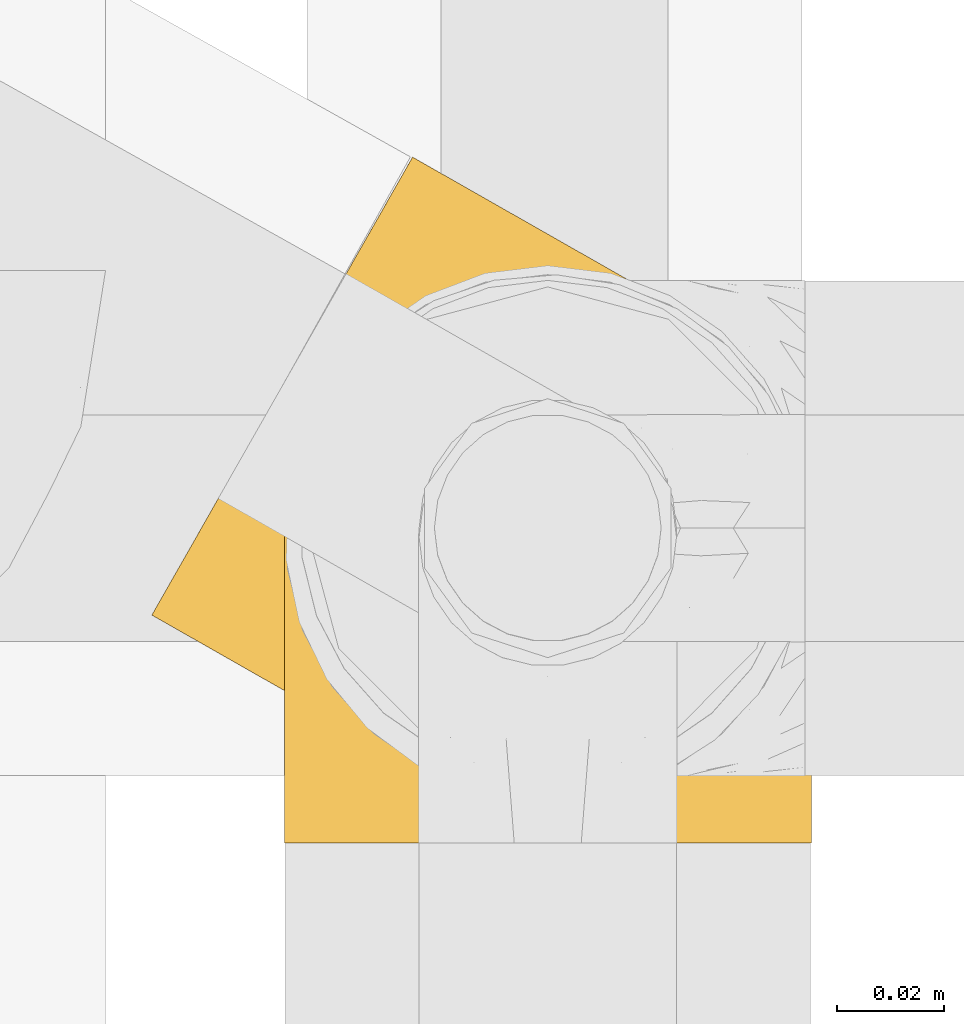
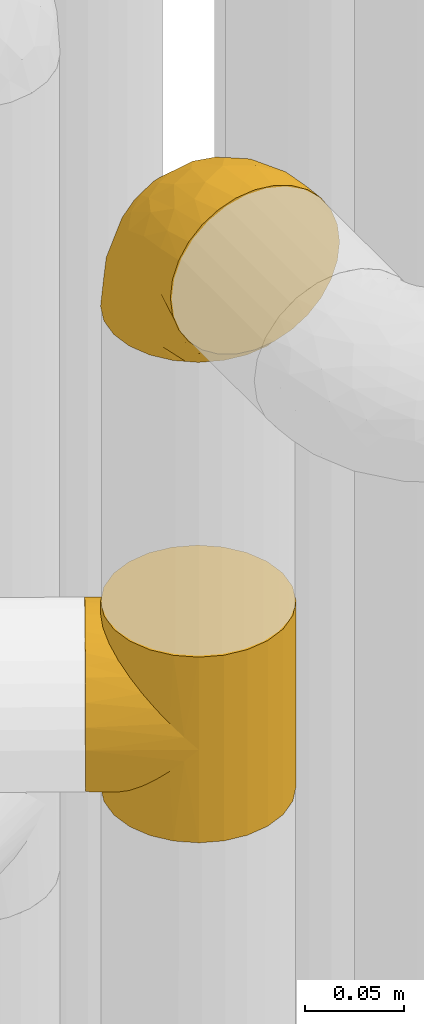
# One storey, part 165 of 827: 2 coverings.
"""IFC2X3 building model written with IfcOpenShell, lengths in millimetres."""

from ifc_helpers import new_model, entity, si_unit, converted_unit, derived_unit, direction, frame, origin, place, context, subcontext, project, spatial, faceted_brep, element, save


model = new_model("IFC2X3")

# Units and contexts
model_context = context("Model", 3, precision=0.01, world=origin(), true_north=direction((6.12303176911189e-17, 1.0)))
body_context = subcontext(model_context, "Body", "Model", "MODEL_VIEW")
ifc_project = project(units=[si_unit("LENGTHUNIT", "METRE", prefix="MILLI"), si_unit("AREAUNIT", "SQUARE_METRE"), si_unit("VOLUMEUNIT", "CUBIC_METRE"), converted_unit("PLANEANGLEUNIT", "DEGREE", entity("IfcRatioMeasure", 0.0174532925199433), si_unit("PLANEANGLEUNIT", "RADIAN"), dimensions=[0, 0, 0, 0, 0, 0, 0]), si_unit("MASSUNIT", "GRAM", prefix="KILO"), derived_unit("MASSDENSITYUNIT", [(si_unit("MASSUNIT", "GRAM", prefix="KILO"), 1), (si_unit("LENGTHUNIT", "METRE"), -3)]), derived_unit("MOMENTOFINERTIAUNIT", [(si_unit("LENGTHUNIT", "METRE"), 4)]), si_unit("TIMEUNIT", "SECOND"), si_unit("FREQUENCYUNIT", "HERTZ"), si_unit("THERMODYNAMICTEMPERATUREUNIT", "DEGREE_CELSIUS"), derived_unit("THERMALTRANSMITTANCEUNIT", [(si_unit("MASSUNIT", "GRAM", prefix="KILO"), 1), (si_unit("THERMODYNAMICTEMPERATUREUNIT", "KELVIN"), -1), (si_unit("TIMEUNIT", "SECOND"), -3)]), derived_unit("VOLUMETRICFLOWRATEUNIT", [(si_unit("LENGTHUNIT", "METRE"), 3), (si_unit("TIMEUNIT", "SECOND"), -1)]), derived_unit("MASSFLOWRATEUNIT", [(si_unit("MASSUNIT", "GRAM", prefix="KILO"), 1), (si_unit("TIMEUNIT", "SECOND"), -1)]), derived_unit("ROTATIONALFREQUENCYUNIT", [(si_unit("TIMEUNIT", "SECOND"), -1)]), si_unit("ELECTRICCURRENTUNIT", "AMPERE"), si_unit("ELECTRICVOLTAGEUNIT", "VOLT"), si_unit("POWERUNIT", "WATT"), si_unit("FORCEUNIT", "NEWTON", prefix="KILO"), si_unit("ILLUMINANCEUNIT", "LUX"), si_unit("LUMINOUSFLUXUNIT", "LUMEN"), si_unit("LUMINOUSINTENSITYUNIT", "CANDELA"), derived_unit("USERDEFINED", [(si_unit("MASSUNIT", "GRAM", prefix="KILO"), -1), (si_unit("LENGTHUNIT", "METRE"), -2), (si_unit("TIMEUNIT", "SECOND"), 3), (si_unit("LUMINOUSFLUXUNIT", "LUMEN"), 1)]), derived_unit("LINEARVELOCITYUNIT", [(si_unit("LENGTHUNIT", "METRE"), 1), (si_unit("TIMEUNIT", "SECOND"), -1)]), si_unit("PRESSUREUNIT", "PASCAL"), derived_unit("USERDEFINED", [(si_unit("LENGTHUNIT", "METRE"), -2), (si_unit("MASSUNIT", "GRAM", prefix="KILO"), 1), (si_unit("TIMEUNIT", "SECOND"), -2)]), derived_unit("LINEARFORCEUNIT", [(si_unit("MASSUNIT", "GRAM", prefix="KILO"), 1), (si_unit("LENGTHUNIT", "METRE"), 1), (si_unit("TIMEUNIT", "SECOND"), -2), (si_unit("LENGTHUNIT", "METRE"), -1)]), derived_unit("PLANARFORCEUNIT", [(si_unit("MASSUNIT", "GRAM", prefix="KILO"), 1), (si_unit("LENGTHUNIT", "METRE"), 1), (si_unit("TIMEUNIT", "SECOND"), -2), (si_unit("LENGTHUNIT", "METRE"), -2)])], contexts=[model_context])

# Site, building, storey
site_placement = place(None, origin())
site = spatial("IfcSite", under=ifc_project, at=site_placement, CompositionType="ELEMENT")
building_placement = place(site_placement, origin())
building = spatial("IfcBuilding", under=site, at=building_placement, CompositionType="ELEMENT")
storey_placement = place(building_placement, frame((0.0, 0.0, 28200.0)))
storey = spatial("IfcBuildingStorey", under=building, at=storey_placement, Name="08", CompositionType="ELEMENT", Elevation=28200.0)

# Coverings
covering_1_placement = place(storey_placement, frame((35653.34, 11503.72, 2248.0)))
element("IfcCovering", 1, at=covering_1_placement, inside=storey, Name=":ADSK_", ObjectType=":ADSK_", PredefinedType="INSULATION", context=body_context, shape_type="Brep", body=[
    faceted_brep([(93.79, 96.34, 50.38), (99.76, 93.46, 0.0), (87.88, 98.3, 0.0), (75.15, 99.89, 0.0), (80.71, 99.61, 37.4), (66.46, 99.07, 25.28), (62.44, 98.14, 0.0), (73.7, 99.86, 31.18), (99.76, 93.46, 57.0), (93.79, 96.34, 63.62), (99.76, 93.46, 114.0), (35.42, 78.88, 8.29), (36.61, 80.17, 0.0), (34.67, 77.62, 0.0), (87.43, 98.41, 43.83), (32.73, 75.06, 7.85), (32.73, 75.06, 0.0), (34.67, 77.62, 114.0), (32.73, 75.06, 106.15), (32.73, 75.06, 114.0), (59.07, 97.09, 19.84), (50.62, 93.16, 0.0), (45.55, 89.22, 0.0), (40.48, 85.29, 0.0), (41.34, 85.85, 10.0), (38.11, 82.7, 8.74), (51.69, 93.77, 15.07), (44.58, 89.0, 11.25), (38.55, 82.73, 0.0), (31.52, 72.09, 0.0), (30.32, 69.12, 0.0), (30.66, 70.32, 8.4), (28.59, 65.57, 8.94), (29.11, 66.15, 0.0), (27.9, 63.18, 0.0), (26.56, 55.83, 12.0), (27.1, 56.81, 0.0), (26.3, 50.45, 0.0), (27.57, 60.7, 10.47), (26.48, 46.46, 16.57), (27.17, 44.09, 0.0), (28.03, 37.82, 22.18), (26.52, 51.14, 14.29), (31.7, 72.69, 8.12), (28.05, 37.74, 0.0), (30.87, 30.04, 28.5), (33.03, 25.91, 0.0), (34.77, 23.16, 35.29), (40.9, 15.78, 0.0), (45.02, 12.15, 49.65), (51.13, 8.03, 0.0), (31.7, 72.69, 105.88), (39.53, 17.2, 42.38), (51.13, 8.03, 57.0), (45.02, 12.15, 64.35), (51.13, 8.03, 114.0), (100.28, 8.33, 114.0), (110.41, 16.2, 114.0), (118.16, 26.43, 114.0), (123.0, 38.31, 114.0), (124.6, 51.04, 114.0), (122.84, 63.75, 114.0), (117.86, 75.58, 114.0), (109.99, 85.71, 114.0), (87.88, 98.3, 114.0), (75.15, 99.89, 114.0), (62.44, 98.14, 114.0), (50.62, 93.16, 114.0), (45.55, 89.22, 114.0), (40.48, 85.29, 114.0), (38.55, 82.73, 114.0), (36.61, 80.17, 114.0), (31.52, 72.09, 114.0), (30.32, 69.12, 114.0), (29.11, 66.15, 114.0), (27.9, 63.18, 114.0), (27.1, 56.81, 114.0), (26.3, 50.45, 114.0), (27.17, 44.09, 114.0), (28.05, 37.74, 114.0), (33.03, 25.91, 114.0), (40.9, 15.78, 114.0), (63.01, 3.19, 114.0), (75.74, 1.6, 114.0), (88.45, 3.35, 114.0), (109.99, 85.71, 0.0), (117.86, 75.58, 0.0), (122.84, 63.75, 0.0), (124.6, 51.04, 0.0), (123.0, 38.31, 0.0), (118.16, 26.43, 0.0), (110.41, 16.2, 0.0), (100.28, 8.33, 0.0), (88.45, 3.35, 0.0), (75.74, 1.6, 0.0), (63.01, 3.19, 0.0), (87.43, 98.41, 70.17), (80.71, 99.61, 76.6), (35.42, 78.88, 105.71), (73.7, 99.86, 82.82), (66.46, 99.07, 88.72), (38.11, 82.7, 105.26), (59.07, 97.09, 94.16), (51.69, 93.77, 98.93), (41.34, 85.85, 104.0), (44.58, 89.0, 102.75), (26.56, 55.83, 102.0), (27.57, 60.7, 103.53), (26.48, 46.46, 97.43), (28.59, 65.57, 105.06), (28.03, 37.82, 91.82), (26.52, 51.14, 99.71), (30.66, 70.32, 105.6), (34.77, 23.16, 78.71), (39.53, 17.2, 71.62), (30.87, 30.04, 85.5), (49.4, 120.2, 44.28), (46.97, 115.94, 32.42), (43.11, 109.15, 22.25), (38.07, 100.3, 14.43), (35.14, 95.15, 11.98), (32.21, 90.0, 9.52), (30.63, 87.24, 9.11), (29.06, 84.47, 8.69), (27.49, 81.71, 8.27), (25.91, 78.95, 7.85), (24.34, 76.18, 8.27), (22.77, 73.42, 8.69), (21.19, 70.65, 9.11), (19.62, 67.89, 9.52), (16.69, 62.74, 11.98), (13.75, 57.59, 14.43), (11.24, 53.17, 18.34), (8.72, 48.74, 22.25), (4.85, 41.96, 32.42), (2.42, 37.69, 44.28), (1.6, 36.23, 57.0), (2.42, 37.69, 69.72), (4.85, 41.96, 81.57), (8.72, 48.74, 91.75), (11.24, 53.17, 95.66), (13.75, 57.59, 99.57), (16.69, 62.74, 102.02), (19.62, 67.89, 104.48), (21.19, 70.65, 104.89), (22.77, 73.42, 105.31), (24.34, 76.18, 105.73), (25.91, 78.95, 106.15), (27.49, 81.71, 105.73), (29.06, 84.47, 105.31), (30.63, 87.24, 104.89), (32.21, 90.0, 104.48), (35.14, 95.15, 102.02), (38.07, 100.3, 99.57), (43.11, 109.15, 91.75), (46.97, 115.94, 81.57), (49.4, 120.2, 69.72), (50.23, 121.66, 57.0)], [[[0, 1, 2]], [[2, 3, 4]], [[5, 3, 6]], [[5, 7, 3]], [[0, 8, 1]], [[8, 9, 10]], [[11, 12, 13]], [[4, 14, 2]], [[7, 4, 3]], [[0, 2, 14]], [[15, 13, 16]], [[17, 18, 19]], [[20, 6, 21]], [[22, 23, 24]], [[15, 11, 13]], [[23, 25, 24]], [[26, 20, 21]], [[27, 21, 22]], [[27, 22, 24]], [[25, 12, 11]], [[25, 23, 28, 12]], [[26, 21, 27]], [[6, 20, 5]], [[29, 30, 31]], [[32, 30, 33, 34]], [[35, 36, 37]], [[38, 36, 35]], [[38, 32, 34]], [[39, 37, 40]], [[41, 39, 40]], [[35, 37, 39, 42]], [[43, 16, 29]], [[40, 44, 41]], [[45, 44, 46]], [[47, 46, 48]], [[49, 48, 50]], [[47, 45, 46]], [[16, 43, 15]], [[51, 19, 18]], [[49, 52, 48]], [[53, 49, 50]], [[54, 53, 55]], [[30, 32, 31]], [[47, 48, 52]], [[36, 38, 34]], [[44, 45, 41]], [[29, 31, 43]], [[56, 57, 58, 59, 60, 61, 62, 63, 10, 64, 65, 66, 67, 68, 69, 70, 71, 17, 19, 72, 73, 74, 75, 76, 77, 78, 79, 80, 81, 55, 82, 83, 84]], [[85, 86, 87, 88, 89, 90, 91, 92, 93, 94, 95, 50, 48, 46, 44, 40, 37, 36, 34, 33, 30, 29, 16, 13, 12, 28, 23, 22, 21, 6, 3, 2, 1]], [[88, 87, 61, 60]], [[58, 90, 89, 59]], [[89, 88, 60, 59]], [[62, 86, 85, 63]], [[1, 8, 10, 63, 85]], [[61, 87, 86, 62]], [[96, 97, 64]], [[18, 17, 98]], [[9, 96, 64]], [[10, 9, 64]], [[65, 99, 100]], [[65, 64, 97]], [[71, 101, 98]], [[65, 100, 66]], [[99, 65, 97]], [[102, 103, 67]], [[104, 68, 105]], [[104, 101, 69]], [[68, 104, 69]], [[103, 105, 67]], [[66, 102, 67]], [[101, 71, 70, 69]], [[68, 67, 105]], [[98, 17, 71]], [[102, 66, 100]], [[106, 76, 107]], [[106, 77, 76]], [[77, 108, 78]], [[109, 75, 74, 73]], [[110, 78, 108]], [[111, 108, 77, 106]], [[19, 51, 72]], [[109, 73, 112]], [[72, 51, 112]], [[76, 75, 107]], [[110, 79, 78]], [[75, 109, 107]], [[113, 114, 81]], [[114, 54, 81]], [[79, 115, 80]], [[115, 79, 110]], [[113, 80, 115]], [[113, 81, 80]], [[54, 55, 81]], [[112, 73, 72]], [[53, 50, 95, 82, 55]], [[82, 95, 94, 83]], [[94, 93, 84, 83]], [[84, 93, 92, 56]], [[56, 92, 91, 57]], [[57, 91, 90, 58]], [[116, 117, 118, 119, 120, 121, 122, 123, 124, 125, 126, 127, 128, 129, 130, 131, 132, 133, 134, 135, 136, 137, 138, 139, 140, 141, 142, 143, 144, 145, 146, 147, 148, 149, 150, 151, 152, 153, 154, 155, 156, 157]], [[25, 123, 122, 121]], [[119, 118, 20]], [[15, 124, 11]], [[27, 120, 119]], [[124, 15, 125]], [[124, 123, 11]], [[120, 24, 121]], [[26, 27, 119]], [[20, 26, 119]], [[24, 120, 27]], [[25, 121, 24]], [[118, 5, 20]], [[7, 5, 117]], [[117, 5, 118]], [[4, 117, 116]], [[0, 116, 157]], [[4, 7, 117]], [[0, 14, 116]], [[8, 0, 157]], [[4, 116, 14]], [[123, 25, 11]], [[9, 157, 156]], [[156, 155, 97]], [[100, 155, 154]], [[100, 99, 155]], [[9, 8, 157]], [[98, 149, 148]], [[97, 96, 156]], [[99, 97, 155]], [[9, 156, 96]], [[18, 148, 147]], [[102, 154, 153]], [[152, 151, 104]], [[18, 98, 148]], [[151, 101, 104]], [[103, 102, 153]], [[105, 153, 152]], [[105, 152, 104]], [[101, 149, 98]], [[101, 151, 150, 149]], [[103, 153, 105]], [[154, 102, 100]], [[146, 145, 112]], [[109, 145, 144, 143]], [[106, 142, 141]], [[107, 142, 106]], [[107, 109, 143]], [[108, 141, 140]], [[110, 108, 140]], [[106, 141, 108, 111]], [[51, 147, 146]], [[140, 139, 110]], [[115, 139, 138]], [[113, 138, 137]], [[54, 137, 136]], [[113, 115, 138]], [[147, 51, 18]], [[54, 114, 137]], [[53, 54, 136]], [[145, 109, 112]], [[113, 137, 114]], [[142, 107, 143]], [[139, 115, 110]], [[146, 112, 51]], [[49, 136, 135]], [[135, 134, 47]], [[45, 134, 133]], [[45, 47, 134]], [[43, 125, 15]], [[49, 53, 136]], [[32, 129, 128, 127]], [[47, 52, 135]], [[49, 135, 52]], [[31, 127, 126]], [[131, 35, 42, 39]], [[125, 43, 126]], [[39, 132, 131]], [[130, 129, 38]], [[43, 31, 126]], [[41, 133, 132]], [[41, 132, 39]], [[35, 130, 38]], [[32, 127, 31]], [[35, 131, 130]], [[129, 32, 38]], [[133, 41, 45]]]),
])
covering_2_placement = place(storey_placement, frame((35678.04, 11495.87, 2541.4)))
element("IfcCovering", 2, at=covering_2_placement, inside=storey, Name=":ADSK_", ObjectType=":ADSK_", PredefinedType="INSULATION", context=body_context, shape_type="Brep", body=[
    faceted_brep([(99.9, 1.6, 58.6), (98.66, 1.6, 69.54), (95.02, 1.6, 79.93), (89.17, 1.6, 89.25), (81.38, 1.6, 97.03), (72.06, 1.6, 102.88), (61.68, 1.6, 106.51), (50.75, 1.6, 107.75), (39.8, 1.6, 106.51), (29.41, 1.6, 102.87), (20.09, 1.6, 97.02), (12.31, 1.6, 89.23), (6.46, 1.6, 79.91), (2.83, 1.6, 69.53), (1.6, 1.6, 58.6), (2.24, 1.6, 52.89), (2.83, 1.6, 47.65), (4.65, 1.6, 42.46), (6.47, 1.6, 37.26), (12.32, 1.6, 27.94), (20.11, 1.6, 20.16), (29.43, 1.6, 14.31), (39.81, 1.6, 10.68), (50.75, 1.6, 9.45), (61.69, 1.6, 10.68), (72.08, 1.6, 14.32), (81.4, 1.6, 20.17), (89.18, 1.6, 27.96), (95.03, 1.6, 37.28), (96.85, 1.6, 42.47), (98.66, 1.6, 47.66), (99.25, 1.6, 52.89), (99.57, 1.6, 55.75), (38.02, 11.12, 1.6), (26.17, 16.03, 1.6), (21.08, 19.94, 1.6), (15.99, 23.84, 1.6), (12.09, 28.93, 1.6), (8.18, 34.02, 1.6), (5.73, 39.95, 1.6), (3.27, 45.87, 1.6), (2.35, 52.86, 1.6), (1.97, 55.73, 1.6), (1.6, 58.6, 1.6), (3.27, 71.32, 1.6), (8.18, 83.17, 1.6), (15.99, 93.35, 1.6), (26.17, 101.16, 1.6), (38.02, 106.07, 1.6), (50.75, 107.75, 1.6), (63.47, 106.07, 1.6), (75.32, 101.16, 1.6), (85.5, 93.35, 1.6), (93.31, 83.17, 1.6), (98.22, 71.32, 1.6), (99.9, 58.6, 1.6), (99.14, 52.86, 1.6), (98.22, 45.87, 1.6), (95.77, 39.95, 1.6), (93.31, 34.02, 1.6), (89.4, 28.93, 1.6), (85.5, 23.84, 1.6), (80.41, 19.94, 1.6), (75.32, 16.03, 1.6), (63.47, 11.12, 1.6), (50.75, 9.45, 1.6), (59.31, 81.82, 69.96), (73.08, 84.02, 59.59), (63.72, 93.05, 51.96), (50.75, 102.55, 34.4), (58.64, 104.83, 23.37), (50.75, 105.83, 13.68), (76.74, 91.87, 41.52), (67.68, 101.74, 26.26), (78.92, 97.07, 20.18), (94.31, 38.45, 72.33), (98.76, 22.17, 65.88), (98.4, 42.04, 57.55), (94.57, 77.69, 23.76), (89.91, 75.76, 46.5), (96.32, 62.11, 46.57), (98.79, 66.08, 21.17), (99.9, 54.26, 23.41), (99.9, 55.35, 17.92), (99.9, 56.44, 12.43), (99.9, 56.98, 9.72), (99.9, 57.52, 7.01), (87.31, 87.84, 26.77), (95.61, 19.41, 76.59), (60.43, 48.89, 95.55), (65.24, 26.34, 102.57), (72.87, 44.55, 92.89), (99.9, 23.41, 54.26), (99.9, 28.03, 51.17), (99.9, 32.65, 48.08), (99.9, 37.28, 44.99), (99.9, 41.9, 41.9), (90.65, 20.6, 85.16), (63.14, 63.36, 85.97), (91.89, 62.21, 59.58), (75.25, 19.94, 99.5), (50.75, 13.68, 105.83), (82.18, 80.85, 53.59), (85.08, 66.53, 67.0), (76.93, 71.06, 71.56), (50.75, 63.99, 87.47), (50.75, 75.73, 75.73), (83.02, 26.77, 92.24), (99.9, 4.31, 58.06), (99.9, 7.01, 57.52), (99.9, 12.43, 56.44), (99.9, 17.92, 55.35), (87.13, 43.43, 81.33), (80.85, 56.23, 80.35), (99.17, 54.97, 39.44), (50.75, 34.4, 102.55), (99.9, 44.99, 37.28), (99.9, 48.08, 32.65), (99.9, 51.17, 28.03), (50.75, 87.47, 63.99), (67.61, 74.55, 74.55), (72.25, 60.86, 83.62), (50.75, 49.19, 95.01), (50.75, 95.01, 49.19), (98.69, 10.27, 46.96), (99.01, 48.79, 8.77), (98.79, 45.16, 18.28), (98.29, 44.99, 11.68), (68.51, 6.17, 11.79), (76.82, 7.65, 15.69), (98.54, 21.59, 42.49), (99.3, 19.96, 47.41), (83.57, 21.0, 7.94), (89.47, 27.2, 9.27), (75.76, 14.83, 7.98), (84.86, 19.7, 13.4), (75.89, 10.93, 13.04), (64.77, 9.63, 7.36), (90.83, 19.97, 23.46), (94.62, 21.13, 30.46), (90.37, 14.14, 26.54), (91.18, 30.2, 6.76), (88.65, 8.12, 26.46), (84.11, 9.93, 20.77), (91.75, 24.62, 20.68), (96.86, 11.87, 40.26), (50.75, 7.15, 7.15), (58.97, 5.32, 9.28), (98.37, 26.68, 38.78), (83.91, 13.92, 18.27), (97.52, 30.67, 31.78), (95.55, 36.65, 12.75), (98.76, 42.89, 22.96), (95.26, 34.04, 17.55), (98.04, 36.6, 27.63), (90.65, 26.41, 15.23), (93.51, 10.07, 33.25), (94.16, 15.83, 32.43), (99.1, 41.99, 27.9), (25.73, 14.83, 7.97), (10.84, 26.4, 15.22), (17.92, 21.01, 7.93), (16.64, 19.71, 13.38), (30.44, 5.72, 13.12), (2.95, 21.6, 42.49), (2.19, 19.96, 47.4), (1.6, 28.03, 51.17), (4.63, 11.87, 40.24), (17.39, 9.93, 20.76), (1.6, 56.44, 12.43), (1.6, 57.52, 7.01), (1.6, 58.06, 4.31), (12.86, 8.13, 26.44), (11.13, 14.15, 26.52), (3.2, 44.99, 11.68), (5.94, 36.65, 12.75), (12.02, 27.21, 9.27), (6.23, 34.04, 17.55), (10.31, 30.2, 6.76), (8.0, 10.06, 33.21), (7.34, 15.83, 32.41), (2.48, 48.79, 8.77), (2.73, 42.89, 22.96), (2.64, 45.38, 18.48), (1.6, 12.43, 56.44), (2.8, 10.28, 46.95), (36.71, 9.64, 7.36), (1.6, 55.35, 17.92), (1.6, 54.26, 23.41), (38.59, 6.05, 9.85), (1.6, 7.01, 57.52), (1.6, 9.72, 56.98), (1.6, 32.65, 48.08), (3.12, 26.68, 38.78), (17.59, 13.92, 18.25), (1.6, 37.28, 44.99), (3.98, 30.66, 31.74), (6.87, 21.14, 30.45), (3.45, 36.59, 27.63), (9.76, 24.6, 20.65), (1.6, 17.92, 55.35), (1.6, 23.41, 54.26), (25.62, 10.93, 13.03), (10.67, 19.97, 23.44), (2.39, 41.99, 27.9), (1.6, 48.08, 32.65), (1.6, 51.17, 28.03), (1.6, 44.99, 37.28), (1.6, 41.9, 41.9), (2.4, 55.26, 39.74), (42.85, 104.83, 23.37), (14.18, 87.84, 26.77), (11.56, 75.91, 46.18), (19.27, 80.84, 53.54), (24.75, 91.87, 41.53), (28.37, 83.98, 59.61), (5.95, 19.16, 76.79), (2.79, 22.37, 66.11), (2.71, 66.08, 21.17), (37.78, 93.05, 51.96), (33.81, 101.74, 26.26), (22.57, 97.07, 20.18), (6.92, 77.69, 23.76), (28.61, 44.55, 92.88), (36.24, 26.34, 102.57), (41.05, 48.9, 95.54), (24.55, 70.99, 71.63), (33.88, 74.55, 74.55), (7.11, 37.8, 72.51), (42.18, 81.82, 69.96), (18.46, 26.77, 92.23), (10.84, 20.6, 85.15), (20.69, 56.15, 80.45), (29.27, 60.85, 83.65), (3.1, 42.06, 57.57), (9.18, 57.03, 63.68), (38.38, 63.4, 85.95), (26.23, 19.94, 99.49), (14.34, 43.59, 81.23), (5.46, 62.61, 47.07), (16.39, 66.52, 66.99)], [[[0, 1, 2, 3, 4, 5, 6, 7, 8, 9, 10, 11, 12, 13, 14, 15, 16, 17, 18, 19, 20, 21, 22, 23, 24, 25, 26, 27, 28, 29, 30, 31, 32]], [[33, 34, 35, 36, 37, 38, 39, 40, 41, 42, 43, 44, 45, 46, 47, 48, 49, 50, 51, 52, 53, 54, 55, 56, 57, 58, 59, 60, 61, 62, 63, 64, 65]], [[66, 67, 68]], [[69, 70, 71]], [[68, 72, 73]], [[73, 72, 74]], [[75, 76, 77]], [[78, 79, 80]], [[51, 50, 73]], [[81, 82, 83, 84, 85, 86, 55]], [[52, 87, 53]], [[74, 52, 51]], [[2, 1, 88]], [[89, 90, 91]], [[77, 92, 93, 94, 95, 96]], [[55, 54, 81]], [[78, 53, 87]], [[5, 90, 6]], [[88, 76, 75]], [[97, 3, 2]], [[89, 91, 98]], [[99, 80, 79]], [[90, 5, 100]], [[74, 87, 52]], [[100, 5, 4]], [[90, 101, 6]], [[79, 102, 103]], [[102, 67, 104]], [[105, 98, 106]], [[107, 4, 3]], [[76, 0, 108, 109, 110, 111, 92]], [[107, 112, 113]], [[114, 77, 96]], [[89, 115, 90]], [[114, 96, 116, 117, 118, 82]], [[75, 97, 88]], [[119, 66, 68]], [[50, 71, 70]], [[100, 91, 90]], [[99, 77, 80]], [[102, 104, 103]], [[97, 107, 3]], [[80, 81, 78]], [[107, 97, 112]], [[68, 73, 70]], [[66, 98, 120]], [[78, 81, 54]], [[114, 81, 80]], [[53, 78, 54]], [[78, 87, 79]], [[102, 87, 72]], [[79, 103, 99]], [[4, 107, 100]], [[91, 100, 107]], [[88, 97, 2]], [[112, 97, 75]], [[99, 112, 75]], [[103, 104, 113]], [[91, 121, 98]], [[89, 105, 122, 115]], [[101, 90, 115]], [[101, 7, 6]], [[88, 1, 76]], [[0, 76, 1]], [[92, 77, 76]], [[73, 74, 51]], [[87, 74, 72]], [[81, 114, 82]], [[77, 114, 80]], [[87, 102, 79]], [[67, 102, 72]], [[68, 67, 72]], [[67, 120, 104]], [[120, 121, 104]], [[104, 121, 113]], [[121, 120, 98]], [[91, 107, 113]], [[91, 113, 121]], [[103, 113, 112]], [[106, 98, 66]], [[105, 89, 98]], [[106, 66, 119]], [[67, 66, 120]], [[68, 69, 123, 119]], [[50, 49, 71]], [[50, 70, 73]], [[112, 99, 103]], [[77, 99, 75]], [[69, 68, 70]], [[29, 124, 110]], [[84, 83, 125]], [[126, 82, 118]], [[59, 58, 127]], [[25, 128, 129]], [[130, 93, 131]], [[132, 62, 133]], [[134, 135, 136]], [[137, 65, 64]], [[64, 134, 137]], [[138, 139, 140]], [[111, 110, 124, 92]], [[134, 136, 137]], [[134, 64, 63]], [[141, 61, 60]], [[125, 58, 57]], [[142, 143, 140]], [[142, 26, 143]], [[127, 83, 82]], [[28, 124, 29]], [[108, 0, 32, 31, 30, 110, 109]], [[30, 29, 110]], [[135, 144, 138]], [[28, 145, 124]], [[57, 56, 55, 86, 85, 84]], [[146, 147, 23]], [[24, 23, 147]], [[25, 143, 26]], [[95, 94, 148]], [[24, 128, 25]], [[149, 138, 143]], [[124, 145, 131]], [[127, 58, 125]], [[150, 148, 139]], [[127, 126, 151]], [[151, 59, 127]], [[152, 151, 126]], [[153, 154, 155]], [[153, 133, 141]], [[145, 28, 27]], [[142, 156, 27]], [[157, 148, 130]], [[61, 133, 62]], [[134, 132, 135]], [[147, 128, 24]], [[65, 137, 146]], [[146, 137, 147]], [[128, 137, 136]], [[137, 128, 147]], [[128, 136, 129]], [[149, 129, 136]], [[25, 129, 143]], [[158, 152, 117]], [[152, 118, 117]], [[153, 151, 152]], [[158, 116, 154]], [[144, 150, 138]], [[153, 152, 158]], [[133, 153, 155]], [[133, 155, 132]], [[141, 60, 151]], [[135, 132, 155]], [[134, 63, 132]], [[144, 135, 155]], [[135, 138, 149]], [[155, 154, 144]], [[150, 154, 96]], [[154, 150, 144]], [[148, 94, 130]], [[82, 126, 127]], [[118, 152, 126]], [[150, 96, 95]], [[139, 148, 157]], [[150, 95, 148]], [[93, 92, 131]], [[130, 145, 156]], [[130, 94, 93]], [[84, 125, 57]], [[127, 125, 83]], [[140, 139, 157]], [[150, 139, 138]], [[140, 157, 142]], [[138, 140, 143]], [[156, 142, 157]], [[27, 26, 142]], [[130, 156, 157]], [[145, 27, 156]], [[132, 63, 62]], [[124, 131, 92]], [[130, 131, 145]], [[129, 149, 143]], [[135, 149, 136]], [[153, 141, 151]], [[59, 151, 60]], [[133, 61, 141]], [[116, 96, 154]], [[153, 158, 154]], [[158, 117, 116]], [[34, 33, 159]], [[160, 161, 162]], [[22, 21, 163]], [[164, 165, 166]], [[19, 18, 167]], [[168, 21, 20]], [[42, 41, 40, 169, 170, 171, 43]], [[172, 173, 168]], [[174, 38, 175]], [[176, 177, 178]], [[179, 164, 180]], [[40, 181, 169]], [[182, 183, 175]], [[17, 184, 185]], [[65, 146, 186]], [[187, 174, 188]], [[23, 22, 189]], [[174, 39, 38]], [[15, 14, 190, 191, 184, 16]], [[181, 40, 39]], [[192, 193, 164]], [[194, 163, 168]], [[33, 186, 159]], [[180, 173, 172]], [[195, 196, 193]], [[18, 185, 167]], [[173, 180, 197]], [[198, 199, 196]], [[200, 201, 185, 184]], [[184, 17, 16]], [[18, 17, 185]], [[202, 159, 186]], [[194, 168, 203]], [[189, 163, 202]], [[204, 205, 182]], [[187, 181, 174]], [[160, 177, 176]], [[206, 183, 182]], [[206, 182, 205]], [[201, 165, 185]], [[165, 164, 167]], [[172, 179, 180]], [[202, 194, 162]], [[176, 161, 160]], [[65, 186, 33]], [[163, 189, 22]], [[175, 177, 182]], [[174, 183, 188]], [[177, 198, 204]], [[199, 160, 162]], [[198, 207, 204]], [[175, 38, 37]], [[198, 177, 160]], [[178, 177, 175]], [[176, 35, 161]], [[34, 159, 161]], [[162, 161, 159]], [[202, 162, 159]], [[199, 162, 203]], [[196, 199, 203]], [[198, 160, 199]], [[193, 197, 180]], [[208, 198, 196]], [[188, 183, 206]], [[175, 183, 174]], [[193, 192, 195]], [[195, 208, 196]], [[197, 196, 203]], [[180, 164, 193]], [[168, 163, 21]], [[166, 165, 201]], [[166, 192, 164]], [[189, 202, 186]], [[186, 146, 189]], [[23, 189, 146]], [[174, 181, 39]], [[169, 181, 187]], [[196, 197, 193]], [[173, 203, 168]], [[203, 173, 197]], [[172, 168, 20]], [[20, 19, 172]], [[179, 172, 19]], [[19, 167, 179]], [[164, 179, 167]], [[35, 176, 36]], [[35, 34, 161]], [[185, 165, 167]], [[162, 194, 203]], [[163, 194, 202]], [[176, 178, 36]], [[37, 36, 178]], [[175, 37, 178]], [[177, 204, 182]], [[207, 198, 208]], [[207, 205, 204]], [[209, 188, 206, 205, 207, 208]], [[48, 210, 71]], [[211, 212, 213]], [[214, 213, 215]], [[216, 217, 13]], [[218, 43, 171, 170, 169, 187, 188]], [[219, 220, 214]], [[47, 46, 221]], [[210, 48, 220]], [[211, 222, 212]], [[222, 45, 44]], [[221, 220, 47]], [[47, 220, 48]], [[221, 211, 214]], [[223, 224, 225]], [[211, 46, 45]], [[226, 227, 215]], [[43, 218, 44]], [[217, 216, 228]], [[219, 215, 229]], [[14, 13, 217]], [[224, 9, 8]], [[10, 230, 11]], [[11, 231, 12]], [[232, 223, 233]], [[234, 208, 195, 192, 166, 201]], [[235, 234, 228]], [[222, 44, 218]], [[106, 229, 236]], [[224, 237, 9]], [[231, 238, 228]], [[9, 237, 10]], [[115, 224, 101]], [[239, 234, 235]], [[231, 11, 230]], [[223, 230, 237]], [[224, 8, 101]], [[223, 236, 233]], [[225, 115, 122, 105]], [[216, 12, 231]], [[209, 234, 239]], [[210, 219, 69]], [[219, 214, 215]], [[229, 119, 219]], [[209, 218, 188]], [[239, 212, 222]], [[239, 222, 218]], [[45, 222, 211]], [[235, 212, 239]], [[213, 212, 240]], [[223, 237, 224]], [[230, 10, 237]], [[238, 231, 230]], [[216, 231, 228]], [[232, 230, 223]], [[235, 238, 240]], [[115, 225, 224]], [[233, 236, 227]], [[8, 7, 101]], [[234, 209, 208]], [[218, 209, 239]], [[217, 228, 234]], [[13, 12, 216]], [[234, 201, 217]], [[217, 201, 200, 184, 191, 190, 14]], [[211, 221, 46]], [[220, 221, 214]], [[71, 210, 69]], [[71, 49, 48]], [[219, 210, 220]], [[226, 215, 213]], [[211, 213, 214]], [[226, 213, 240]], [[215, 227, 229]], [[232, 240, 238]], [[233, 227, 226]], [[232, 233, 226]], [[236, 223, 225]], [[240, 232, 226]], [[232, 238, 230]], [[225, 105, 236]], [[236, 105, 106]], [[236, 229, 227]], [[123, 69, 219, 119]], [[106, 119, 229]], [[238, 235, 228]], [[212, 235, 240]]]),
])

save(model, "model.ifc")
